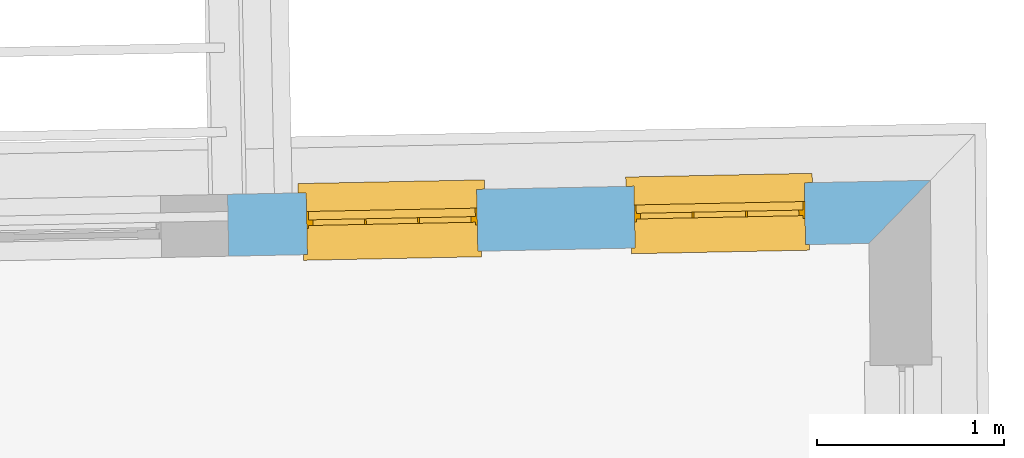
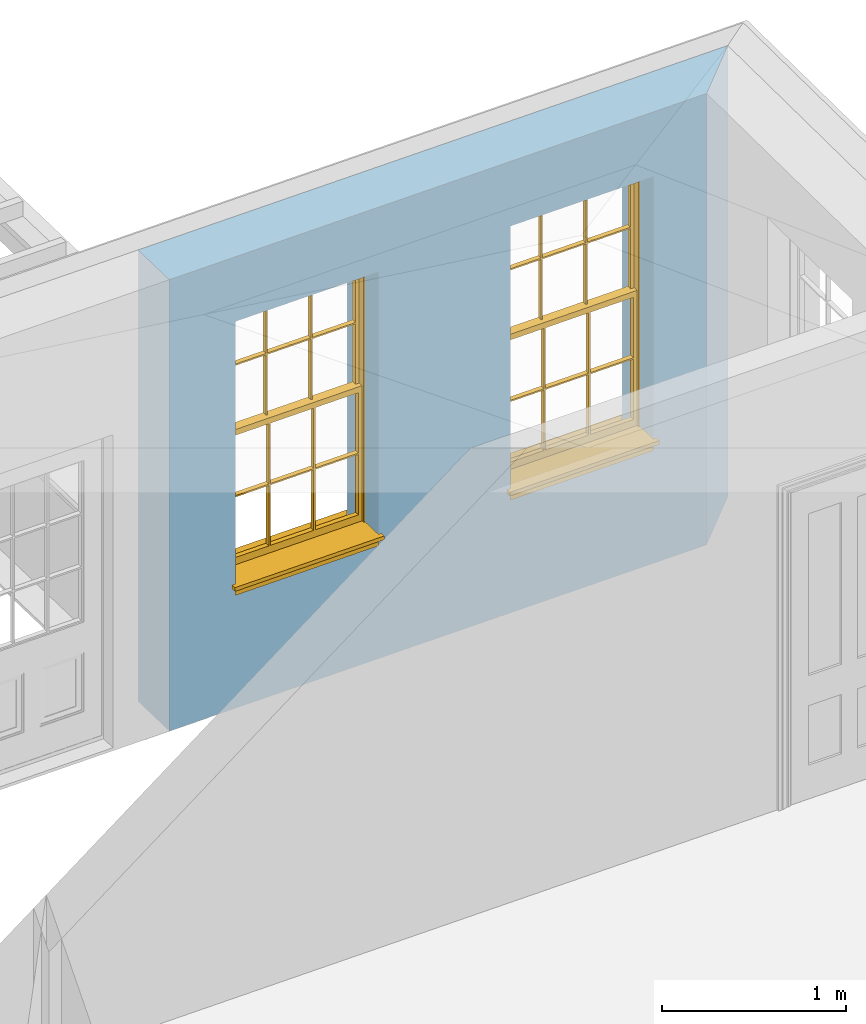
# One storey, part 9 of 11: 2 windows, 2 openings, plus 1 element that does not belong to this part.
"""IFC2X3 building model written with IfcOpenShell, lengths in metres."""

from ifc_helpers import new_model, si_unit, frame, origin, place, context, subcontext, project, spatial, polyline, outline, extrude, faceted_brep, material, layer, layer_set, layer_usage, element, fill, save


model = new_model("IFC2X3")

# Units and contexts
model_context = context("Model", 3, world=origin())
body_context = subcontext(model_context, "Body", "Model", "MODEL_VIEW")
ifc_project = project(units=[si_unit("PLANEANGLEUNIT", "RADIAN"), si_unit("MASSUNIT", "GRAM", prefix="KILO"), si_unit("FORCEUNIT", "NEWTON", prefix="KILO"), si_unit("LENGTHUNIT", "METRE")], contexts=[model_context])

# Site, building, storey
site_placement = place(None, origin())
site = spatial("IfcSite", under=ifc_project, at=site_placement, CompositionType="ELEMENT")
building_placement = place(None, origin())
building = spatial("IfcBuilding", under=site, at=building_placement, Name="Building plot-11", CompositionType="ELEMENT")
storey_placement = place(None, frame((0.0, 0.0, 5.3)))
storey = spatial("IfcBuildingStorey", under=building, at=storey_placement, Name="Floor 1", CompositionType="ELEMENT", Elevation=5.3)

# Wall, openings, windows
ifc_material = material(Name="Masonry")
ifc_layer = layer(ifc_material, 0.33, ventilated=False)
ifc_layer_set = layer_set([ifc_layer], Name="My Wall")
ifc_layer_usage = layer_usage(ifc_layer_set, "AXIS2", "NEGATIVE", 0.08)
wall_placement = place(storey_placement, origin())
wall = element("IfcWallStandardCase", 1, at=wall_placement, inside=storey, material=ifc_layer_usage, Name="exterior", context=body_context, shape_type="SweptSolid", body=[
    extrude(outline(polyline([(65.4938070899396, 22.718638343531), (65.820935630786, 23.0552457674694), (62.0708365057897, 22.9802565983485), (62.0774340593141, 22.6503225560195), (65.4938070899396, 22.718638343531)])), origin(), (0.0, 0.0, 1.0), 3.0),
])
opening_1_placement = place(storey_placement, frame((0.0, 0.0, 0.75)))
opening_1 = element("IfcOpeningElement", 2, at=opening_1_placement, cuts=wall, Name="Opening", ObjectType="Opening", context=body_context, shape_type="SweptSolid", body=[
    extrude(outline(polyline([(65.1487028088251, 23.0418034079227), (64.2388846921, 23.0236101542645), (64.2454822456244, 22.6936761119355), (65.1553003623496, 22.7118693655938), (65.1487028088251, 23.0418034079227)])), origin(), (0.0, 0.0, 1.0), 1.82),
])
opening_2_placement = place(storey_placement, frame((0.0, 0.0, 0.75)))
opening_2 = element("IfcOpeningElement", 3, at=opening_2_placement, cuts=wall, Name="Opening", ObjectType="Opening", context=body_context, shape_type="SweptSolid", body=[
    extrude(outline(polyline([(63.4000646457099, 23.006836619426), (62.4902465289847, 22.9886433657677), (62.4968440825092, 22.6587093234388), (63.4066621992343, 22.676902577097), (63.4000646457099, 23.006836619426)])), origin(), (0.0, 0.0, 1.0), 1.82),
])
window_1_placement = place(storey_placement, frame((65.1537009554346, 22.7918533758553, 0.75), z_axis=(0.0, 0.0, 1.0), x_axis=(-0.909818116725162, -0.018193253658243, 0.0)))
window_1 = element("IfcWindow", 4, at=window_1_placement, inside=storey, Name="circulation outside window", OverallHeight=1.82, OverallWidth=0.91, context=body_context, shape_type="Brep", held_by="IfcProductRepresentation", body=[
    faceted_brep([(0.033125, -0.105, 0.975209), (0.01, -0.105, 0.975209), (0.033125, -0.105, 1.376042), (0.876875, -0.105, 0.975209), (0.876875, -0.105, 1.376042), (0.9, -0.105, 0.975209), (0.876875, -0.105, 1.386042), (0.876875, -0.105, 1.786875), (0.9, -0.105, 1.81), (0.033125, -0.105, 1.786875), (0.033125, -0.105, 1.386042), (0.01, -0.105, 1.81), (0.876875, -0.135, 1.376042), (0.876875, -0.135, 0.975209), (0.9, -0.135, 0.937083), (0.033125, -0.135, 1.786875), (0.01, -0.135, 1.81), (0.033125, -0.135, 1.386042), (0.01, -0.135, 0.937083), (0.033125, -0.135, 0.975209), (0.033125, -0.135, 1.376042), (0.876875, -0.135, 1.786875), (0.876875, -0.135, 1.386042), (0.9, -0.135, 1.81), (0.033125, -0.105, 0.937083), (0.01, -0.105, 0.937083), (0.033125, -0.105, 0.53625), (0.876875, -0.105, 0.937083), (0.876875, -0.105, 0.53625), (0.9, -0.105, 0.937083), (0.876875, -0.105, 0.52625), (0.876875, -0.105, 0.125417), (0.9, -0.105, 0.077167), (0.033125, -0.105, 0.125417), (0.033125, -0.105, 0.52625), (0.01, -0.105, 0.077167), (-0.0425, -0.25, 0.01), (-0.0425, -0.3, 0.001667), (0.0, -0.25, 0.01), (0.9525, -0.25, 0.01), (0.91, -0.25, 0.01), (0.9525, -0.3, 0.001667), (-0.02, 0.08, 0.077167), (0.0, 0.08, 0.077167), (-0.02, 0.11, 0.077167), (0.0, -0.06, 0.077167), (0.01, -0.06, 0.077167), (0.91, -0.06, 0.077167), (0.91, 0.08, 0.077167), (0.9, -0.06, 0.077167), (0.93, 0.08, 0.077167), (0.93, 0.11, 0.077167), (0.01, -0.075, 0.975209), (0.9, -0.075, 0.975209), (0.876875, -0.075, 0.125417), (0.876875, -0.075, 0.52625), (0.9, -0.075, 0.077167), (0.876875, -0.075, 0.53625), (0.876875, -0.075, 0.937083), (0.033125, -0.075, 0.125417), (0.01, -0.075, 0.077167), (0.033125, -0.075, 0.52625), (0.033125, -0.075, 0.937083), (0.033125, -0.075, 0.53625), (-0.02, 0.08, 0.052167), (-0.02, 0.11, 0.052167), (0.93, 0.11, 0.052167), (0.93, 0.08, 0.052167), (0.91, 0.08, 0.052167), (0.0, 0.08, 0.052167), (0.91, -0.15, 0.026667), (0.0, -0.15, 0.026667), (-0.0425, -0.3, -0.123333), (0.9525, -0.3, -0.123333), (-0.0425, -0.25, -0.123333), (0.9525, -0.25, -0.123333), (0.01, -0.06, 1.81), (0.9, -0.06, 1.81), (0.0, -0.06, 1.82), (0.91, -0.06, 1.82), (0.01, -0.15, 0.077167), (0.9, -0.15, 0.077167), (0.592292, -0.105, 0.125417), (0.592292, -0.075, 0.125417), (0.317708, -0.075, 0.125417), (0.317708, -0.105, 0.125417), (0.592292, -0.105, 0.53625), (0.317708, -0.105, 0.53625), (0.317708, -0.105, 0.52625), (0.592292, -0.105, 0.52625), (0.592292, -0.075, 0.53625), (0.317708, -0.075, 0.53625), (0.592292, -0.135, 1.386042), (0.592292, -0.105, 1.386042), (0.317708, -0.105, 1.386042), (0.317708, -0.135, 1.386042), (0.317708, -0.135, 1.376042), (0.592292, -0.135, 1.376042), (0.317708, -0.105, 1.376042), (0.592292, -0.105, 1.376042), (0.602292, -0.135, 1.376042), (0.592292, -0.135, 0.975209), (0.602292, -0.135, 0.975209), (0.602292, -0.105, 0.975209), (0.592292, -0.105, 0.975209), (0.602292, -0.105, 1.376042), (0.602292, -0.075, 0.53625), (0.602292, -0.105, 0.53625), (0.317708, -0.075, 0.52625), (0.307708, -0.075, 0.125417), (0.307708, -0.075, 0.52625), (0.602292, -0.075, 0.52625), (0.602292, -0.075, 0.125417), (0.592292, -0.075, 0.52625), (0.307708, -0.075, 0.53625), (0.317708, -0.075, 0.937083), (0.307708, -0.075, 0.937083), (0.602292, -0.075, 0.937083), (0.592292, -0.075, 0.937083), (0.307708, -0.105, 0.52625), (0.307708, -0.105, 0.125417), (0.307708, -0.105, 0.53625), (0.307708, -0.105, 0.937083), (0.592292, -0.105, 0.937083), (0.317708, -0.105, 0.937083), (0.602292, -0.105, 0.937083), (0.602292, -0.105, 0.52625), (0.602292, -0.105, 0.125417), (0.307708, -0.135, 1.386042), (0.307708, -0.135, 1.376042), (0.307708, -0.135, 0.975209), (0.317708, -0.135, 0.975209), (0.317708, -0.135, 1.786875), (0.307708, -0.135, 1.786875), (0.602292, -0.135, 1.786875), (0.592292, -0.135, 1.786875), (0.602292, -0.135, 1.386042), (0.602292, -0.105, 1.386042), (0.307708, -0.105, 1.386042), (0.307708, -0.105, 1.786875), (0.317708, -0.105, 1.786875), (0.592292, -0.105, 1.786875), (0.602292, -0.105, 1.786875), (0.307708, -0.105, 1.376042), (0.317708, -0.105, 0.975209), (0.307708, -0.105, 0.975209), (0.91, -0.15, 1.82), (0.9, -0.15, 1.81), (0.01, -0.15, 1.81), (0.0, -0.15, 1.82), (0.91, -0.25, 0.0), (0.0, -0.25, 0.0), (0.91, 0.08, 0.0), (0.0, 0.08, 0.0)], [[[0, 1, 2]], [[3, 4, 5]], [[6, 7, 8]], [[9, 10, 11]], [[12, 13, 14]], [[15, 16, 17]], [[18, 19, 20]], [[21, 22, 23]], [[24, 25, 26]], [[27, 28, 29]], [[30, 31, 32]], [[33, 34, 35]], [[14, 27, 29]], [[25, 24, 18]], [[36, 37, 38]], [[39, 40, 41]], [[42, 43, 44]], [[45, 46, 43]], [[47, 48, 49]], [[50, 51, 48]], [[1, 0, 52]], [[5, 53, 3]], [[54, 55, 56]], [[57, 58, 53]], [[59, 60, 61]], [[62, 63, 52]], [[48, 43, 46, 49]], [[51, 44, 43, 48]], [[64, 42, 44, 65]], [[65, 44, 51, 66]], [[66, 51, 50, 67]], [[65, 66, 68, 69]], [[60, 56, 49, 46]], [[70, 71, 38, 40]], [[37, 41, 40, 38]], [[37, 72, 73, 41]], [[74, 75, 73, 72]], [[8, 11, 76, 77]], [[76, 78, 79, 77]], [[32, 35, 80, 81]], [[81, 80, 71, 70]], [[82, 83, 84, 85]], [[86, 87, 88, 89]], [[86, 90, 91, 87]], [[92, 93, 94, 95]], [[92, 95, 96, 97]], [[96, 98, 99, 97]], [[100, 97, 101, 102]], [[103, 104, 99, 105]], [[97, 99, 104, 101]], [[102, 103, 105, 100]], [[28, 57, 106, 107]], [[108, 84, 109, 110]], [[111, 112, 83, 113]], [[114, 110, 61, 63]], [[90, 113, 108, 91]], [[115, 91, 114, 116]], [[117, 106, 90, 118]], [[111, 106, 57, 55]], [[119, 110, 109, 120]], [[34, 61, 110, 119]], [[89, 113, 83, 82]], [[88, 108, 113, 89]], [[85, 84, 108, 88]], [[121, 114, 63, 26]], [[122, 116, 114, 121]], [[123, 118, 90, 86]], [[87, 91, 115, 124]], [[107, 106, 117, 125]], [[126, 111, 55, 30]], [[127, 112, 111, 126]], [[126, 30, 28, 107]], [[88, 119, 120, 85]], [[126, 89, 82, 127]], [[125, 123, 86, 107]], [[121, 26, 34, 119]], [[124, 122, 121, 87]], [[128, 17, 20, 129]], [[96, 129, 130, 131]], [[132, 133, 128, 95]], [[134, 135, 92, 136]], [[100, 12, 22, 136]], [[137, 6, 4, 105]], [[94, 138, 139, 140]], [[137, 93, 141, 142]], [[99, 98, 94, 93]], [[143, 2, 10, 138]], [[144, 145, 143, 98]], [[129, 143, 145, 130]], [[20, 2, 143, 129]], [[131, 144, 98, 96]], [[128, 138, 10, 17]], [[133, 139, 138, 128]], [[135, 141, 93, 92]], [[95, 94, 140, 132]], [[22, 6, 137, 136]], [[136, 137, 142, 134]], [[100, 105, 4, 12]], [[107, 86, 89, 126]], [[106, 111, 113, 90]], [[91, 108, 110, 114]], [[87, 121, 119, 88]], [[97, 100, 136, 92]], [[129, 96, 95, 128]], [[98, 143, 138, 94]], [[105, 99, 93, 137]], [[131, 101, 104, 144]], [[124, 115, 118, 123]], [[132, 140, 141, 135]], [[120, 109, 59, 33]], [[15, 9, 139, 133]], [[134, 142, 7, 21]], [[31, 54, 112, 127]], [[36, 74, 72, 37]], [[39, 41, 73, 75]], [[18, 14, 101, 131]], [[23, 16, 132, 135]], [[83, 56, 60, 84]], [[52, 53, 118, 115]], [[53, 52, 144, 104]], [[11, 8, 141, 140]], [[14, 18, 124, 123]], [[2, 1, 11, 10]], [[8, 5, 4, 6]], [[57, 53, 56, 55]], [[60, 52, 63, 61]], [[26, 25, 35, 34]], [[32, 29, 28, 30]], [[14, 23, 22, 12]], [[18, 20, 17, 16]], [[19, 0, 2, 20]], [[17, 10, 9, 15]], [[12, 4, 3, 13]], [[21, 7, 6, 22]], [[27, 58, 57, 28]], [[30, 55, 54, 31]], [[33, 59, 61, 34]], [[26, 63, 62, 24]], [[5, 8, 77, 53]], [[76, 11, 1, 52]], [[46, 45, 78, 76]], [[49, 77, 79, 47]], [[70, 146, 147, 81]], [[71, 80, 148, 149]], [[19, 130, 145, 0]], [[102, 13, 3, 103]], [[116, 122, 24, 62]], [[29, 32, 81, 14]], [[80, 35, 25, 18]], [[60, 46, 76, 52]], [[77, 49, 56, 53]], [[23, 14, 81, 147]], [[16, 148, 80, 18]], [[35, 85, 120]], [[120, 33, 35]], [[127, 82, 32]], [[32, 31, 127]], [[32, 82, 85, 35]], [[102, 101, 14]], [[14, 13, 102]], [[18, 131, 130]], [[130, 19, 18]], [[134, 21, 23]], [[23, 135, 134]], [[16, 15, 133]], [[133, 132, 16]], [[11, 140, 139]], [[139, 9, 11]], [[142, 141, 8]], [[8, 7, 142]], [[23, 147, 148, 16]], [[146, 149, 148, 147]], [[52, 115, 116]], [[116, 62, 52]], [[118, 53, 117]], [[58, 117, 53]], [[27, 125, 117, 58]], [[56, 83, 112]], [[112, 54, 56]], [[109, 84, 60]], [[60, 59, 109]], [[125, 27, 14]], [[14, 123, 125]], [[122, 124, 18]], [[18, 24, 122]], [[145, 144, 52]], [[52, 0, 145]], [[103, 3, 53]], [[53, 104, 103]], [[79, 78, 149, 146]], [[78, 45, 71, 149]], [[146, 70, 47, 79]], [[150, 75, 74, 151]], [[68, 66, 67]], [[48, 68, 67, 50]], [[69, 64, 65]], [[42, 64, 69, 43]], [[69, 68, 152, 153]], [[70, 68, 48, 47]], [[150, 152, 68, 70]], [[43, 69, 71, 45]], [[69, 153, 151, 71]], [[152, 150, 151, 153]], [[38, 151, 74, 36]], [[71, 151, 38]], [[39, 75, 150, 40]], [[40, 150, 70]]]),
])
fill(opening_1, window_1)
window_2_placement = place(storey_placement, frame((63.4050627923193, 22.7568865873586, 0.75), z_axis=(0.0, 0.0, 1.0), x_axis=(-0.909818116725162, -0.018193253658243, 0.0)))
window_2 = element("IfcWindow", 5, at=window_2_placement, inside=storey, Name="circulation outside window", OverallHeight=1.82, OverallWidth=0.91, context=body_context, shape_type="Brep", held_by="IfcProductRepresentation", body=[
    faceted_brep([(0.033125, -0.105, 0.975209), (0.01, -0.105, 0.975209), (0.033125, -0.105, 1.376042), (0.876875, -0.105, 0.975209), (0.876875, -0.105, 1.376042), (0.9, -0.105, 0.975209), (0.876875, -0.105, 1.386042), (0.876875, -0.105, 1.786875), (0.9, -0.105, 1.81), (0.033125, -0.105, 1.786875), (0.033125, -0.105, 1.386042), (0.01, -0.105, 1.81), (0.876875, -0.135, 1.376042), (0.876875, -0.135, 0.975209), (0.9, -0.135, 0.937083), (0.033125, -0.135, 1.786875), (0.01, -0.135, 1.81), (0.033125, -0.135, 1.386042), (0.01, -0.135, 0.937083), (0.033125, -0.135, 0.975209), (0.033125, -0.135, 1.376042), (0.876875, -0.135, 1.786875), (0.876875, -0.135, 1.386042), (0.9, -0.135, 1.81), (0.033125, -0.105, 0.937083), (0.01, -0.105, 0.937083), (0.033125, -0.105, 0.53625), (0.876875, -0.105, 0.937083), (0.876875, -0.105, 0.53625), (0.9, -0.105, 0.937083), (0.876875, -0.105, 0.52625), (0.876875, -0.105, 0.125417), (0.9, -0.105, 0.077167), (0.033125, -0.105, 0.125417), (0.033125, -0.105, 0.52625), (0.01, -0.105, 0.077167), (-0.0425, -0.25, 0.01), (-0.0425, -0.3, 0.001667), (0.0, -0.25, 0.01), (0.9525, -0.25, 0.01), (0.91, -0.25, 0.01), (0.9525, -0.3, 0.001667), (-0.02, 0.08, 0.077167), (0.0, 0.08, 0.077167), (-0.02, 0.11, 0.077167), (0.0, -0.06, 0.077167), (0.01, -0.06, 0.077167), (0.91, -0.06, 0.077167), (0.91, 0.08, 0.077167), (0.9, -0.06, 0.077167), (0.93, 0.08, 0.077167), (0.93, 0.11, 0.077167), (0.01, -0.075, 0.975209), (0.9, -0.075, 0.975209), (0.876875, -0.075, 0.125417), (0.876875, -0.075, 0.52625), (0.9, -0.075, 0.077167), (0.876875, -0.075, 0.53625), (0.876875, -0.075, 0.937083), (0.033125, -0.075, 0.125417), (0.01, -0.075, 0.077167), (0.033125, -0.075, 0.52625), (0.033125, -0.075, 0.937083), (0.033125, -0.075, 0.53625), (-0.02, 0.08, 0.052167), (-0.02, 0.11, 0.052167), (0.93, 0.11, 0.052167), (0.93, 0.08, 0.052167), (0.91, 0.08, 0.052167), (0.0, 0.08, 0.052167), (0.91, -0.15, 0.026667), (0.0, -0.15, 0.026667), (-0.0425, -0.3, -0.123333), (0.9525, -0.3, -0.123333), (-0.0425, -0.25, -0.123333), (0.9525, -0.25, -0.123333), (0.01, -0.06, 1.81), (0.9, -0.06, 1.81), (0.0, -0.06, 1.82), (0.91, -0.06, 1.82), (0.01, -0.15, 0.077167), (0.9, -0.15, 0.077167), (0.592292, -0.105, 0.125417), (0.592292, -0.075, 0.125417), (0.317708, -0.075, 0.125417), (0.317708, -0.105, 0.125417), (0.592292, -0.105, 0.53625), (0.317708, -0.105, 0.53625), (0.317708, -0.105, 0.52625), (0.592292, -0.105, 0.52625), (0.592292, -0.075, 0.53625), (0.317708, -0.075, 0.53625), (0.592292, -0.135, 1.386042), (0.592292, -0.105, 1.386042), (0.317708, -0.105, 1.386042), (0.317708, -0.135, 1.386042), (0.317708, -0.135, 1.376042), (0.592292, -0.135, 1.376042), (0.317708, -0.105, 1.376042), (0.592292, -0.105, 1.376042), (0.602292, -0.135, 1.376042), (0.592292, -0.135, 0.975209), (0.602292, -0.135, 0.975209), (0.602292, -0.105, 0.975209), (0.592292, -0.105, 0.975209), (0.602292, -0.105, 1.376042), (0.602292, -0.075, 0.53625), (0.602292, -0.105, 0.53625), (0.317708, -0.075, 0.52625), (0.307708, -0.075, 0.125417), (0.307708, -0.075, 0.52625), (0.602292, -0.075, 0.52625), (0.602292, -0.075, 0.125417), (0.592292, -0.075, 0.52625), (0.307708, -0.075, 0.53625), (0.317708, -0.075, 0.937083), (0.307708, -0.075, 0.937083), (0.602292, -0.075, 0.937083), (0.592292, -0.075, 0.937083), (0.307708, -0.105, 0.52625), (0.307708, -0.105, 0.125417), (0.307708, -0.105, 0.53625), (0.307708, -0.105, 0.937083), (0.592292, -0.105, 0.937083), (0.317708, -0.105, 0.937083), (0.602292, -0.105, 0.937083), (0.602292, -0.105, 0.52625), (0.602292, -0.105, 0.125417), (0.307708, -0.135, 1.386042), (0.307708, -0.135, 1.376042), (0.307708, -0.135, 0.975209), (0.317708, -0.135, 0.975209), (0.317708, -0.135, 1.786875), (0.307708, -0.135, 1.786875), (0.602292, -0.135, 1.786875), (0.592292, -0.135, 1.786875), (0.602292, -0.135, 1.386042), (0.602292, -0.105, 1.386042), (0.307708, -0.105, 1.386042), (0.307708, -0.105, 1.786875), (0.317708, -0.105, 1.786875), (0.592292, -0.105, 1.786875), (0.602292, -0.105, 1.786875), (0.307708, -0.105, 1.376042), (0.317708, -0.105, 0.975209), (0.307708, -0.105, 0.975209), (0.91, -0.15, 1.82), (0.9, -0.15, 1.81), (0.01, -0.15, 1.81), (0.0, -0.15, 1.82), (0.91, -0.25, 0.0), (0.0, -0.25, 0.0), (0.91, 0.08, 0.0), (0.0, 0.08, 0.0)], [[[0, 1, 2]], [[3, 4, 5]], [[6, 7, 8]], [[9, 10, 11]], [[12, 13, 14]], [[15, 16, 17]], [[18, 19, 20]], [[21, 22, 23]], [[24, 25, 26]], [[27, 28, 29]], [[30, 31, 32]], [[33, 34, 35]], [[14, 27, 29]], [[25, 24, 18]], [[36, 37, 38]], [[39, 40, 41]], [[42, 43, 44]], [[45, 46, 43]], [[47, 48, 49]], [[50, 51, 48]], [[1, 0, 52]], [[5, 53, 3]], [[54, 55, 56]], [[57, 58, 53]], [[59, 60, 61]], [[62, 63, 52]], [[48, 43, 46, 49]], [[51, 44, 43, 48]], [[64, 42, 44, 65]], [[65, 44, 51, 66]], [[66, 51, 50, 67]], [[65, 66, 68, 69]], [[60, 56, 49, 46]], [[70, 71, 38, 40]], [[37, 41, 40, 38]], [[37, 72, 73, 41]], [[74, 75, 73, 72]], [[8, 11, 76, 77]], [[76, 78, 79, 77]], [[32, 35, 80, 81]], [[81, 80, 71, 70]], [[82, 83, 84, 85]], [[86, 87, 88, 89]], [[86, 90, 91, 87]], [[92, 93, 94, 95]], [[92, 95, 96, 97]], [[96, 98, 99, 97]], [[100, 97, 101, 102]], [[103, 104, 99, 105]], [[97, 99, 104, 101]], [[102, 103, 105, 100]], [[28, 57, 106, 107]], [[108, 84, 109, 110]], [[111, 112, 83, 113]], [[114, 110, 61, 63]], [[90, 113, 108, 91]], [[115, 91, 114, 116]], [[117, 106, 90, 118]], [[111, 106, 57, 55]], [[119, 110, 109, 120]], [[34, 61, 110, 119]], [[89, 113, 83, 82]], [[88, 108, 113, 89]], [[85, 84, 108, 88]], [[121, 114, 63, 26]], [[122, 116, 114, 121]], [[123, 118, 90, 86]], [[87, 91, 115, 124]], [[107, 106, 117, 125]], [[126, 111, 55, 30]], [[127, 112, 111, 126]], [[126, 30, 28, 107]], [[88, 119, 120, 85]], [[126, 89, 82, 127]], [[125, 123, 86, 107]], [[121, 26, 34, 119]], [[124, 122, 121, 87]], [[128, 17, 20, 129]], [[96, 129, 130, 131]], [[132, 133, 128, 95]], [[134, 135, 92, 136]], [[100, 12, 22, 136]], [[137, 6, 4, 105]], [[94, 138, 139, 140]], [[137, 93, 141, 142]], [[99, 98, 94, 93]], [[143, 2, 10, 138]], [[144, 145, 143, 98]], [[129, 143, 145, 130]], [[20, 2, 143, 129]], [[131, 144, 98, 96]], [[128, 138, 10, 17]], [[133, 139, 138, 128]], [[135, 141, 93, 92]], [[95, 94, 140, 132]], [[22, 6, 137, 136]], [[136, 137, 142, 134]], [[100, 105, 4, 12]], [[107, 86, 89, 126]], [[106, 111, 113, 90]], [[91, 108, 110, 114]], [[87, 121, 119, 88]], [[97, 100, 136, 92]], [[129, 96, 95, 128]], [[98, 143, 138, 94]], [[105, 99, 93, 137]], [[131, 101, 104, 144]], [[124, 115, 118, 123]], [[132, 140, 141, 135]], [[120, 109, 59, 33]], [[15, 9, 139, 133]], [[134, 142, 7, 21]], [[31, 54, 112, 127]], [[36, 74, 72, 37]], [[39, 41, 73, 75]], [[18, 14, 101, 131]], [[23, 16, 132, 135]], [[83, 56, 60, 84]], [[52, 53, 118, 115]], [[53, 52, 144, 104]], [[11, 8, 141, 140]], [[14, 18, 124, 123]], [[2, 1, 11, 10]], [[8, 5, 4, 6]], [[57, 53, 56, 55]], [[60, 52, 63, 61]], [[26, 25, 35, 34]], [[32, 29, 28, 30]], [[14, 23, 22, 12]], [[18, 20, 17, 16]], [[19, 0, 2, 20]], [[17, 10, 9, 15]], [[12, 4, 3, 13]], [[21, 7, 6, 22]], [[27, 58, 57, 28]], [[30, 55, 54, 31]], [[33, 59, 61, 34]], [[26, 63, 62, 24]], [[5, 8, 77, 53]], [[76, 11, 1, 52]], [[46, 45, 78, 76]], [[49, 77, 79, 47]], [[70, 146, 147, 81]], [[71, 80, 148, 149]], [[19, 130, 145, 0]], [[102, 13, 3, 103]], [[116, 122, 24, 62]], [[29, 32, 81, 14]], [[80, 35, 25, 18]], [[60, 46, 76, 52]], [[77, 49, 56, 53]], [[23, 14, 81, 147]], [[16, 148, 80, 18]], [[35, 85, 120]], [[120, 33, 35]], [[127, 82, 32]], [[32, 31, 127]], [[32, 82, 85, 35]], [[102, 101, 14]], [[14, 13, 102]], [[18, 131, 130]], [[130, 19, 18]], [[134, 21, 23]], [[23, 135, 134]], [[16, 15, 133]], [[133, 132, 16]], [[11, 140, 139]], [[139, 9, 11]], [[142, 141, 8]], [[8, 7, 142]], [[23, 147, 148, 16]], [[146, 149, 148, 147]], [[52, 115, 116]], [[116, 62, 52]], [[118, 53, 117]], [[58, 117, 53]], [[27, 125, 117, 58]], [[56, 83, 112]], [[112, 54, 56]], [[109, 84, 60]], [[60, 59, 109]], [[125, 27, 14]], [[14, 123, 125]], [[122, 124, 18]], [[18, 24, 122]], [[145, 144, 52]], [[52, 0, 145]], [[103, 3, 53]], [[53, 104, 103]], [[79, 78, 149, 146]], [[78, 45, 71, 149]], [[146, 70, 47, 79]], [[150, 75, 74, 151]], [[68, 66, 67]], [[48, 68, 67, 50]], [[69, 64, 65]], [[42, 64, 69, 43]], [[69, 68, 152, 153]], [[70, 68, 48, 47]], [[150, 152, 68, 70]], [[43, 69, 71, 45]], [[69, 153, 151, 71]], [[152, 150, 151, 153]], [[38, 151, 74, 36]], [[71, 151, 38]], [[39, 75, 150, 40]], [[40, 150, 70]]]),
])
fill(opening_2, window_2)

save(model, "model.ifc")
